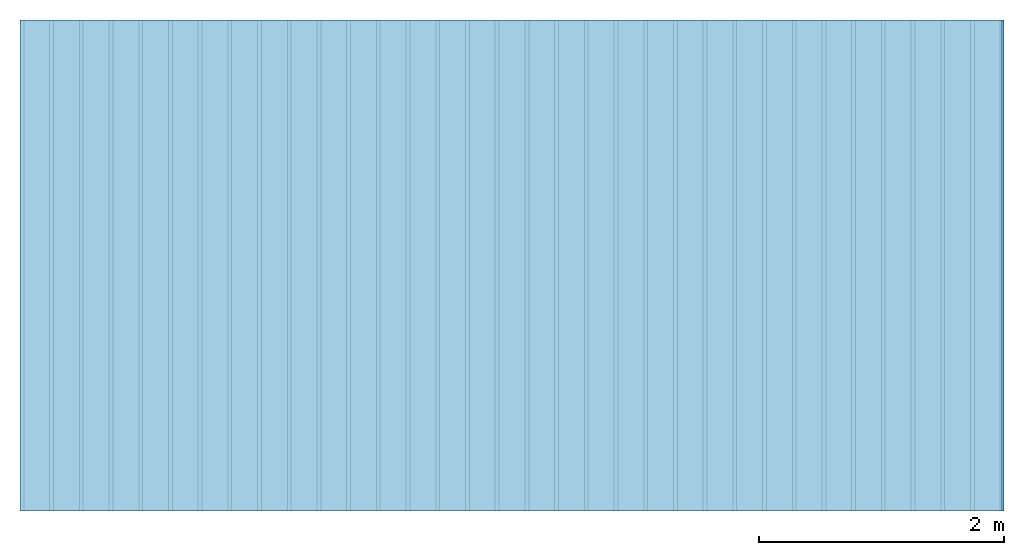
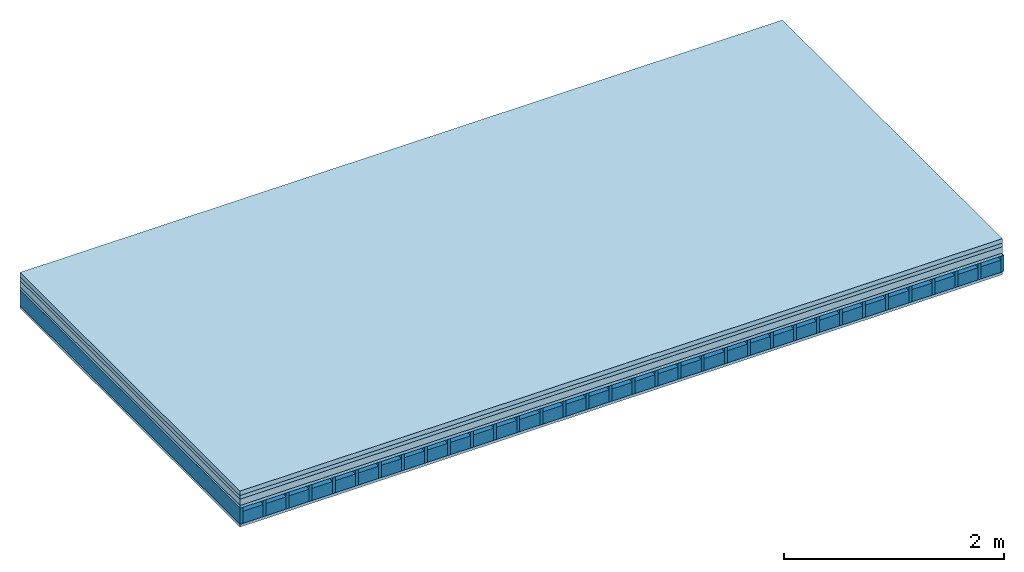
# One storey: 5 plates, 2 members, 1 element without a shape of its own.
"""IFC4 building model written with IfcOpenShell, lengths in metres."""

from ifc_helpers import new_model, si_unit, derived_unit, direction, frame, frame_2d, origin, origin_with_axes, place, context, project, spatial, rectangle, extrude, material, layer, layer_set, type_object, element, aggregate, save


model = new_model("IFC4")

# Units and contexts
plan_context = context("Plan", 3, precision=1e-05, world=origin(), true_north=direction((0.0, 1.0)))
model_context = context("Model", 3, precision=1e-05, world=origin(), true_north=direction((0.0, 1.0)))
ifc_project = project(units=[si_unit("LENGTHUNIT", "METRE"), derived_unit("SOUNDPRESSUREUNIT", [(si_unit("PRESSUREUNIT", "PASCAL", prefix="MICRO"), 0)]), si_unit("ENERGYUNIT", "JOULE", prefix="MEGA"), si_unit("MASSUNIT", "GRAM", prefix="KILO"), derived_unit("THERMALTRANSMITTANCEUNIT", [(si_unit("POWERUNIT", "WATT"), 1), (si_unit("AREAUNIT", "SQUARE_METRE"), -1), (si_unit("THERMODYNAMICTEMPERATUREUNIT", "KELVIN"), -1)]), derived_unit("AREADENSITYUNIT", [(si_unit("MASSUNIT", "GRAM", prefix="KILO"), 1), (si_unit("AREAUNIT", "SQUARE_METRE"), -1)]), derived_unit("USERDEFINED", [(si_unit("ENERGYUNIT", "JOULE", prefix="MEGA"), 1), (si_unit("AREAUNIT", "SQUARE_METRE"), -1)])], contexts=[plan_context, model_context])

# Site, building, storey
site = spatial("IfcSite", under=ifc_project)
building_placement = place(None, origin())
building = spatial("IfcBuilding", under=site, at=building_placement)
storey_placement = place(building_placement, origin())
storey = spatial("IfcBuildingStorey", under=building, at=storey_placement)

# Slab, members, plates
ifc_material_1 = material(Name="Cement screed", Category="04.006")
ifc_layer_1 = layer(ifc_material_1, 0.05, Name="On-material")
ifc_material_2 = material(Name="EP1, 40/35mm")
ifc_layer_2 = layer(ifc_material_2, 0.04, Name="Impact sound insulation")
ifc_material_3 = material(Category="03.011")
ifc_layer_3 = layer(ifc_material_3, 0.07, Name="on Supporting structure")
ifc_material_4 = material(Name="surface element sheathing above")
ifc_layer_4 = layer(ifc_material_4, 0.031, Name="Sub-floor")
ifc_layer_5 = layer(None, 0.178, Name="Supporting structure")
ifc_material_5 = material(Name="surface element sheathing below")
ifc_layer_6 = layer(ifc_material_5, 0.031, Name="Lower layer 1")
ifc_layer_set = layer_set([ifc_layer_1, ifc_layer_2, ifc_layer_3, ifc_layer_4, ifc_layer_5, ifc_layer_6])
slab_type = type_object("IfcSlabType", Name="A1466", PredefinedType="NOTDEFINED", material=ifc_layer_set)
slab_placement = place(None, frame((0.0, 0.0, 0.0), z_axis=(0.0, 0.0, -1.0), x_axis=(1.0, 0.0, 0.0)))
slab = element("IfcSlab", 1, at=slab_placement, inside=storey, type_object=slab_type, material=ifc_layer_set, Name="Slab #1")
ifc_material_6 = material(Name="surface element LFE 12")
member_1_placement = place(slab_placement, origin())
member_1 = element("IfcMember", 2, at=member_1_placement, material=ifc_material_6, Name="Supporting structure", context=plan_context, shape_type="SweptSolid", body=[
    extrude(rectangle(XDim=0.031, YDim=0.178, at=frame_2d((0.0155, 0.089), x_axis=(1.0, 0.0))), frame((0.0, 4.0, 0.191), z_axis=(0.0, -1.0, 0.0), x_axis=(1.0, 0.0, 0.0)), (0.0, 0.0, 1.0), 4.0),
    extrude(rectangle(XDim=0.031, YDim=0.178, at=frame_2d((0.0155, 0.089), x_axis=(1.0, 0.0))), frame((0.242, 4.0, 0.191), z_axis=(0.0, -1.0, 0.0), x_axis=(1.0, 0.0, 0.0)), (0.0, 0.0, 1.0), 4.0),
    extrude(rectangle(XDim=0.031, YDim=0.178, at=frame_2d((0.0155, 0.089), x_axis=(1.0, 0.0))), frame((0.484, 4.0, 0.191), z_axis=(0.0, -1.0, 0.0), x_axis=(1.0, 0.0, 0.0)), (0.0, 0.0, 1.0), 4.0),
    extrude(rectangle(XDim=0.031, YDim=0.178, at=frame_2d((0.0155, 0.089), x_axis=(1.0, 0.0))), frame((0.726, 4.0, 0.191), z_axis=(0.0, -1.0, 0.0), x_axis=(1.0, 0.0, 0.0)), (0.0, 0.0, 1.0), 4.0),
    extrude(rectangle(XDim=0.031, YDim=0.178, at=frame_2d((0.0155, 0.089), x_axis=(1.0, 0.0))), frame((0.968, 4.0, 0.191), z_axis=(0.0, -1.0, 0.0), x_axis=(1.0, 0.0, 0.0)), (0.0, 0.0, 1.0), 4.0),
    extrude(rectangle(XDim=0.031, YDim=0.178, at=frame_2d((0.0155, 0.089), x_axis=(1.0, 0.0))), frame((1.21, 4.0, 0.191), z_axis=(0.0, -1.0, 0.0), x_axis=(1.0, 0.0, 0.0)), (0.0, 0.0, 1.0), 4.0),
    extrude(rectangle(XDim=0.031, YDim=0.178, at=frame_2d((0.0155, 0.089), x_axis=(1.0, 0.0))), frame((1.452, 4.0, 0.191), z_axis=(0.0, -1.0, 0.0), x_axis=(1.0, 0.0, 0.0)), (0.0, 0.0, 1.0), 4.0),
    extrude(rectangle(XDim=0.031, YDim=0.178, at=frame_2d((0.0155, 0.089), x_axis=(1.0, 0.0))), frame((1.694, 4.0, 0.191), z_axis=(0.0, -1.0, 0.0), x_axis=(1.0, 0.0, 0.0)), (0.0, 0.0, 1.0), 4.0),
    extrude(rectangle(XDim=0.031, YDim=0.178, at=frame_2d((0.0155, 0.089), x_axis=(1.0, 0.0))), frame((1.936, 4.0, 0.191), z_axis=(0.0, -1.0, 0.0), x_axis=(1.0, 0.0, 0.0)), (0.0, 0.0, 1.0), 4.0),
    extrude(rectangle(XDim=0.031, YDim=0.178, at=frame_2d((0.0155, 0.089), x_axis=(1.0, 0.0))), frame((2.178, 4.0, 0.191), z_axis=(0.0, -1.0, 0.0), x_axis=(1.0, 0.0, 0.0)), (0.0, 0.0, 1.0), 4.0),
    extrude(rectangle(XDim=0.031, YDim=0.178, at=frame_2d((0.0155, 0.089), x_axis=(1.0, 0.0))), frame((2.42, 4.0, 0.191), z_axis=(0.0, -1.0, 0.0), x_axis=(1.0, 0.0, 0.0)), (0.0, 0.0, 1.0), 4.0),
    extrude(rectangle(XDim=0.031, YDim=0.178, at=frame_2d((0.0155, 0.089), x_axis=(1.0, 0.0))), frame((2.662, 4.0, 0.191), z_axis=(0.0, -1.0, 0.0), x_axis=(1.0, 0.0, 0.0)), (0.0, 0.0, 1.0), 4.0),
    extrude(rectangle(XDim=0.031, YDim=0.178, at=frame_2d((0.0155, 0.089), x_axis=(1.0, 0.0))), frame((2.904, 4.0, 0.191), z_axis=(0.0, -1.0, 0.0), x_axis=(1.0, 0.0, 0.0)), (0.0, 0.0, 1.0), 4.0),
    extrude(rectangle(XDim=0.031, YDim=0.178, at=frame_2d((0.0155, 0.089), x_axis=(1.0, 0.0))), frame((3.146, 4.0, 0.191), z_axis=(0.0, -1.0, 0.0), x_axis=(1.0, 0.0, 0.0)), (0.0, 0.0, 1.0), 4.0),
    extrude(rectangle(XDim=0.031, YDim=0.178, at=frame_2d((0.0155, 0.089), x_axis=(1.0, 0.0))), frame((3.388, 4.0, 0.191), z_axis=(0.0, -1.0, 0.0), x_axis=(1.0, 0.0, 0.0)), (0.0, 0.0, 1.0), 4.0),
    extrude(rectangle(XDim=0.031, YDim=0.178, at=frame_2d((0.0155, 0.089), x_axis=(1.0, 0.0))), frame((3.63, 4.0, 0.191), z_axis=(0.0, -1.0, 0.0), x_axis=(1.0, 0.0, 0.0)), (0.0, 0.0, 1.0), 4.0),
    extrude(rectangle(XDim=0.031, YDim=0.178, at=frame_2d((0.0155, 0.089), x_axis=(1.0, 0.0))), frame((3.872, 4.0, 0.191), z_axis=(0.0, -1.0, 0.0), x_axis=(1.0, 0.0, 0.0)), (0.0, 0.0, 1.0), 4.0),
    extrude(rectangle(XDim=0.031, YDim=0.178, at=frame_2d((0.0155, 0.089), x_axis=(1.0, 0.0))), frame((4.114, 4.0, 0.191), z_axis=(0.0, -1.0, 0.0), x_axis=(1.0, 0.0, 0.0)), (0.0, 0.0, 1.0), 4.0),
    extrude(rectangle(XDim=0.031, YDim=0.178, at=frame_2d((0.0155, 0.089), x_axis=(1.0, 0.0))), frame((4.356, 4.0, 0.191), z_axis=(0.0, -1.0, 0.0), x_axis=(1.0, 0.0, 0.0)), (0.0, 0.0, 1.0), 4.0),
    extrude(rectangle(XDim=0.031, YDim=0.178, at=frame_2d((0.0155, 0.089), x_axis=(1.0, 0.0))), frame((4.598, 4.0, 0.191), z_axis=(0.0, -1.0, 0.0), x_axis=(1.0, 0.0, 0.0)), (0.0, 0.0, 1.0), 4.0),
    extrude(rectangle(XDim=0.031, YDim=0.178, at=frame_2d((0.0155, 0.089), x_axis=(1.0, 0.0))), frame((4.84, 4.0, 0.191), z_axis=(0.0, -1.0, 0.0), x_axis=(1.0, 0.0, 0.0)), (0.0, 0.0, 1.0), 4.0),
    extrude(rectangle(XDim=0.031, YDim=0.178, at=frame_2d((0.0155, 0.089), x_axis=(1.0, 0.0))), frame((5.082, 4.0, 0.191), z_axis=(0.0, -1.0, 0.0), x_axis=(1.0, 0.0, 0.0)), (0.0, 0.0, 1.0), 4.0),
    extrude(rectangle(XDim=0.031, YDim=0.178, at=frame_2d((0.0155, 0.089), x_axis=(1.0, 0.0))), frame((5.324, 4.0, 0.191), z_axis=(0.0, -1.0, 0.0), x_axis=(1.0, 0.0, 0.0)), (0.0, 0.0, 1.0), 4.0),
    extrude(rectangle(XDim=0.031, YDim=0.178, at=frame_2d((0.0155, 0.089), x_axis=(1.0, 0.0))), frame((5.566, 4.0, 0.191), z_axis=(0.0, -1.0, 0.0), x_axis=(1.0, 0.0, 0.0)), (0.0, 0.0, 1.0), 4.0),
    extrude(rectangle(XDim=0.031, YDim=0.178, at=frame_2d((0.0155, 0.089), x_axis=(1.0, 0.0))), frame((5.808, 4.0, 0.191), z_axis=(0.0, -1.0, 0.0), x_axis=(1.0, 0.0, 0.0)), (0.0, 0.0, 1.0), 4.0),
    extrude(rectangle(XDim=0.031, YDim=0.178, at=frame_2d((0.0155, 0.089), x_axis=(1.0, 0.0))), frame((6.05, 4.0, 0.191), z_axis=(0.0, -1.0, 0.0), x_axis=(1.0, 0.0, 0.0)), (0.0, 0.0, 1.0), 4.0),
    extrude(rectangle(XDim=0.031, YDim=0.178, at=frame_2d((0.0155, 0.089), x_axis=(1.0, 0.0))), frame((6.292, 4.0, 0.191), z_axis=(0.0, -1.0, 0.0), x_axis=(1.0, 0.0, 0.0)), (0.0, 0.0, 1.0), 4.0),
    extrude(rectangle(XDim=0.031, YDim=0.178, at=frame_2d((0.0155, 0.089), x_axis=(1.0, 0.0))), frame((6.534, 4.0, 0.191), z_axis=(0.0, -1.0, 0.0), x_axis=(1.0, 0.0, 0.0)), (0.0, 0.0, 1.0), 4.0),
    extrude(rectangle(XDim=0.031, YDim=0.178, at=frame_2d((0.0155, 0.089), x_axis=(1.0, 0.0))), frame((6.776, 4.0, 0.191), z_axis=(0.0, -1.0, 0.0), x_axis=(1.0, 0.0, 0.0)), (0.0, 0.0, 1.0), 4.0),
    extrude(rectangle(XDim=0.031, YDim=0.178, at=frame_2d((0.0155, 0.089), x_axis=(1.0, 0.0))), frame((7.018, 4.0, 0.191), z_axis=(0.0, -1.0, 0.0), x_axis=(1.0, 0.0, 0.0)), (0.0, 0.0, 1.0), 4.0),
    extrude(rectangle(XDim=0.031, YDim=0.178, at=frame_2d((0.0155, 0.089), x_axis=(1.0, 0.0))), frame((7.26, 4.0, 0.191), z_axis=(0.0, -1.0, 0.0), x_axis=(1.0, 0.0, 0.0)), (0.0, 0.0, 1.0), 4.0),
    extrude(rectangle(XDim=0.031, YDim=0.178, at=frame_2d((0.0155, 0.089), x_axis=(1.0, 0.0))), frame((7.502, 4.0, 0.191), z_axis=(0.0, -1.0, 0.0), x_axis=(1.0, 0.0, 0.0)), (0.0, 0.0, 1.0), 4.0),
    extrude(rectangle(XDim=0.031, YDim=0.178, at=frame_2d((0.0155, 0.089), x_axis=(1.0, 0.0))), frame((7.744, 4.0, 0.191), z_axis=(0.0, -1.0, 0.0), x_axis=(1.0, 0.0, 0.0)), (0.0, 0.0, 1.0), 4.0),
    extrude(rectangle(XDim=0.031, YDim=0.178, at=frame_2d((0.0155, 0.089), x_axis=(1.0, 0.0))), frame((7.986, 4.0, 0.191), z_axis=(0.0, -1.0, 0.0), x_axis=(1.0, 0.0, 0.0)), (0.0, 0.0, 1.0), 4.0),
])
ifc_material_7 = material(Name="Damper LFE 12")
member_2_placement = place(slab_placement, origin())
member_2 = element("IfcMember", 3, at=member_2_placement, material=ifc_material_7, Name="in supporting structure", context=plan_context, shape_type="SweptSolid", body=[
    extrude(rectangle(XDim=0.211, YDim=0.135, at=frame_2d((0.1055, 0.0675), x_axis=(1.0, 0.0))), frame((0.031, 4.0, 0.234), z_axis=(0.0, -1.0, 0.0), x_axis=(1.0, 0.0, 0.0)), (0.0, 0.0, 1.0), 4.0),
    extrude(rectangle(XDim=0.211, YDim=0.135, at=frame_2d((0.1055, 0.0675), x_axis=(1.0, 0.0))), frame((0.273, 4.0, 0.234), z_axis=(0.0, -1.0, 0.0), x_axis=(1.0, 0.0, 0.0)), (0.0, 0.0, 1.0), 4.0),
    extrude(rectangle(XDim=0.211, YDim=0.135, at=frame_2d((0.1055, 0.0675), x_axis=(1.0, 0.0))), frame((0.515, 4.0, 0.234), z_axis=(0.0, -1.0, 0.0), x_axis=(1.0, 0.0, 0.0)), (0.0, 0.0, 1.0), 4.0),
    extrude(rectangle(XDim=0.211, YDim=0.135, at=frame_2d((0.1055, 0.0675), x_axis=(1.0, 0.0))), frame((0.757, 4.0, 0.234), z_axis=(0.0, -1.0, 0.0), x_axis=(1.0, 0.0, 0.0)), (0.0, 0.0, 1.0), 4.0),
    extrude(rectangle(XDim=0.211, YDim=0.135, at=frame_2d((0.1055, 0.0675), x_axis=(1.0, 0.0))), frame((0.999, 4.0, 0.234), z_axis=(0.0, -1.0, 0.0), x_axis=(1.0, 0.0, 0.0)), (0.0, 0.0, 1.0), 4.0),
    extrude(rectangle(XDim=0.211, YDim=0.135, at=frame_2d((0.1055, 0.0675), x_axis=(1.0, 0.0))), frame((1.241, 4.0, 0.234), z_axis=(0.0, -1.0, 0.0), x_axis=(1.0, 0.0, 0.0)), (0.0, 0.0, 1.0), 4.0),
    extrude(rectangle(XDim=0.211, YDim=0.135, at=frame_2d((0.1055, 0.0675), x_axis=(1.0, 0.0))), frame((1.483, 4.0, 0.234), z_axis=(0.0, -1.0, 0.0), x_axis=(1.0, 0.0, 0.0)), (0.0, 0.0, 1.0), 4.0),
    extrude(rectangle(XDim=0.211, YDim=0.135, at=frame_2d((0.1055, 0.0675), x_axis=(1.0, 0.0))), frame((1.725, 4.0, 0.234), z_axis=(0.0, -1.0, 0.0), x_axis=(1.0, 0.0, 0.0)), (0.0, 0.0, 1.0), 4.0),
    extrude(rectangle(XDim=0.211, YDim=0.135, at=frame_2d((0.1055, 0.0675), x_axis=(1.0, 0.0))), frame((1.967, 4.0, 0.234), z_axis=(0.0, -1.0, 0.0), x_axis=(1.0, 0.0, 0.0)), (0.0, 0.0, 1.0), 4.0),
    extrude(rectangle(XDim=0.211, YDim=0.135, at=frame_2d((0.1055, 0.0675), x_axis=(1.0, 0.0))), frame((2.209, 4.0, 0.234), z_axis=(0.0, -1.0, 0.0), x_axis=(1.0, 0.0, 0.0)), (0.0, 0.0, 1.0), 4.0),
    extrude(rectangle(XDim=0.211, YDim=0.135, at=frame_2d((0.1055, 0.0675), x_axis=(1.0, 0.0))), frame((2.451, 4.0, 0.234), z_axis=(0.0, -1.0, 0.0), x_axis=(1.0, 0.0, 0.0)), (0.0, 0.0, 1.0), 4.0),
    extrude(rectangle(XDim=0.211, YDim=0.135, at=frame_2d((0.1055, 0.0675), x_axis=(1.0, 0.0))), frame((2.693, 4.0, 0.234), z_axis=(0.0, -1.0, 0.0), x_axis=(1.0, 0.0, 0.0)), (0.0, 0.0, 1.0), 4.0),
    extrude(rectangle(XDim=0.211, YDim=0.135, at=frame_2d((0.1055, 0.0675), x_axis=(1.0, 0.0))), frame((2.935, 4.0, 0.234), z_axis=(0.0, -1.0, 0.0), x_axis=(1.0, 0.0, 0.0)), (0.0, 0.0, 1.0), 4.0),
    extrude(rectangle(XDim=0.211, YDim=0.135, at=frame_2d((0.1055, 0.0675), x_axis=(1.0, 0.0))), frame((3.177, 4.0, 0.234), z_axis=(0.0, -1.0, 0.0), x_axis=(1.0, 0.0, 0.0)), (0.0, 0.0, 1.0), 4.0),
    extrude(rectangle(XDim=0.211, YDim=0.135, at=frame_2d((0.1055, 0.0675), x_axis=(1.0, 0.0))), frame((3.419, 4.0, 0.234), z_axis=(0.0, -1.0, 0.0), x_axis=(1.0, 0.0, 0.0)), (0.0, 0.0, 1.0), 4.0),
    extrude(rectangle(XDim=0.211, YDim=0.135, at=frame_2d((0.1055, 0.0675), x_axis=(1.0, 0.0))), frame((3.661, 4.0, 0.234), z_axis=(0.0, -1.0, 0.0), x_axis=(1.0, 0.0, 0.0)), (0.0, 0.0, 1.0), 4.0),
    extrude(rectangle(XDim=0.211, YDim=0.135, at=frame_2d((0.1055, 0.0675), x_axis=(1.0, 0.0))), frame((3.903, 4.0, 0.234), z_axis=(0.0, -1.0, 0.0), x_axis=(1.0, 0.0, 0.0)), (0.0, 0.0, 1.0), 4.0),
    extrude(rectangle(XDim=0.211, YDim=0.135, at=frame_2d((0.1055, 0.0675), x_axis=(1.0, 0.0))), frame((4.145, 4.0, 0.234), z_axis=(0.0, -1.0, 0.0), x_axis=(1.0, 0.0, 0.0)), (0.0, 0.0, 1.0), 4.0),
    extrude(rectangle(XDim=0.211, YDim=0.135, at=frame_2d((0.1055, 0.0675), x_axis=(1.0, 0.0))), frame((4.387, 4.0, 0.234), z_axis=(0.0, -1.0, 0.0), x_axis=(1.0, 0.0, 0.0)), (0.0, 0.0, 1.0), 4.0),
    extrude(rectangle(XDim=0.211, YDim=0.135, at=frame_2d((0.1055, 0.0675), x_axis=(1.0, 0.0))), frame((4.629, 4.0, 0.234), z_axis=(0.0, -1.0, 0.0), x_axis=(1.0, 0.0, 0.0)), (0.0, 0.0, 1.0), 4.0),
    extrude(rectangle(XDim=0.211, YDim=0.135, at=frame_2d((0.1055, 0.0675), x_axis=(1.0, 0.0))), frame((4.871, 4.0, 0.234), z_axis=(0.0, -1.0, 0.0), x_axis=(1.0, 0.0, 0.0)), (0.0, 0.0, 1.0), 4.0),
    extrude(rectangle(XDim=0.211, YDim=0.135, at=frame_2d((0.1055, 0.0675), x_axis=(1.0, 0.0))), frame((5.113, 4.0, 0.234), z_axis=(0.0, -1.0, 0.0), x_axis=(1.0, 0.0, 0.0)), (0.0, 0.0, 1.0), 4.0),
    extrude(rectangle(XDim=0.211, YDim=0.135, at=frame_2d((0.1055, 0.0675), x_axis=(1.0, 0.0))), frame((5.355, 4.0, 0.234), z_axis=(0.0, -1.0, 0.0), x_axis=(1.0, 0.0, 0.0)), (0.0, 0.0, 1.0), 4.0),
    extrude(rectangle(XDim=0.211, YDim=0.135, at=frame_2d((0.1055, 0.0675), x_axis=(1.0, 0.0))), frame((5.597, 4.0, 0.234), z_axis=(0.0, -1.0, 0.0), x_axis=(1.0, 0.0, 0.0)), (0.0, 0.0, 1.0), 4.0),
    extrude(rectangle(XDim=0.211, YDim=0.135, at=frame_2d((0.1055, 0.0675), x_axis=(1.0, 0.0))), frame((5.839, 4.0, 0.234), z_axis=(0.0, -1.0, 0.0), x_axis=(1.0, 0.0, 0.0)), (0.0, 0.0, 1.0), 4.0),
    extrude(rectangle(XDim=0.211, YDim=0.135, at=frame_2d((0.1055, 0.0675), x_axis=(1.0, 0.0))), frame((6.081, 4.0, 0.234), z_axis=(0.0, -1.0, 0.0), x_axis=(1.0, 0.0, 0.0)), (0.0, 0.0, 1.0), 4.0),
    extrude(rectangle(XDim=0.211, YDim=0.135, at=frame_2d((0.1055, 0.0675), x_axis=(1.0, 0.0))), frame((6.323, 4.0, 0.234), z_axis=(0.0, -1.0, 0.0), x_axis=(1.0, 0.0, 0.0)), (0.0, 0.0, 1.0), 4.0),
    extrude(rectangle(XDim=0.211, YDim=0.135, at=frame_2d((0.1055, 0.0675), x_axis=(1.0, 0.0))), frame((6.565, 4.0, 0.234), z_axis=(0.0, -1.0, 0.0), x_axis=(1.0, 0.0, 0.0)), (0.0, 0.0, 1.0), 4.0),
    extrude(rectangle(XDim=0.211, YDim=0.135, at=frame_2d((0.1055, 0.0675), x_axis=(1.0, 0.0))), frame((6.807, 4.0, 0.234), z_axis=(0.0, -1.0, 0.0), x_axis=(1.0, 0.0, 0.0)), (0.0, 0.0, 1.0), 4.0),
    extrude(rectangle(XDim=0.211, YDim=0.135, at=frame_2d((0.1055, 0.0675), x_axis=(1.0, 0.0))), frame((7.049, 4.0, 0.234), z_axis=(0.0, -1.0, 0.0), x_axis=(1.0, 0.0, 0.0)), (0.0, 0.0, 1.0), 4.0),
    extrude(rectangle(XDim=0.211, YDim=0.135, at=frame_2d((0.1055, 0.0675), x_axis=(1.0, 0.0))), frame((7.291, 4.0, 0.234), z_axis=(0.0, -1.0, 0.0), x_axis=(1.0, 0.0, 0.0)), (0.0, 0.0, 1.0), 4.0),
    extrude(rectangle(XDim=0.211, YDim=0.135, at=frame_2d((0.1055, 0.0675), x_axis=(1.0, 0.0))), frame((7.533, 4.0, 0.234), z_axis=(0.0, -1.0, 0.0), x_axis=(1.0, 0.0, 0.0)), (0.0, 0.0, 1.0), 4.0),
    extrude(rectangle(XDim=0.211, YDim=0.135, at=frame_2d((0.1055, 0.0675), x_axis=(1.0, 0.0))), frame((7.775, 4.0, 0.234), z_axis=(0.0, -1.0, 0.0), x_axis=(1.0, 0.0, 0.0)), (0.0, 0.0, 1.0), 4.0),
])
plate_1_placement = place(slab_placement, origin())
plate_1 = element("IfcPlate", 4, at=plate_1_placement, material=ifc_material_1, Name="On-material", context=plan_context, shape_type="SweptSolid", body=[
    extrude(rectangle(XDim=8.0, YDim=4.0, at=frame_2d((4.0, 2.0), x_axis=(1.0, 0.0))), origin_with_axes(), (0.0, 0.0, 1.0), 0.05),
])
plate_2_placement = place(slab_placement, origin())
plate_2 = element("IfcPlate", 5, at=plate_2_placement, material=ifc_material_2, Name="Impact sound insulation", context=plan_context, shape_type="SweptSolid", body=[
    extrude(rectangle(XDim=8.0, YDim=4.0, at=frame_2d((4.0, 2.0), x_axis=(1.0, 0.0))), frame((0.0, 0.0, 0.05), z_axis=(0.0, 0.0, 1.0), x_axis=(1.0, 0.0, 0.0)), (0.0, 0.0, 1.0), 0.04),
])
plate_3_placement = place(slab_placement, origin())
plate_3 = element("IfcPlate", 6, at=plate_3_placement, material=ifc_material_3, Name="on Supporting structure", context=plan_context, shape_type="SweptSolid", body=[
    extrude(rectangle(XDim=8.0, YDim=4.0, at=frame_2d((4.0, 2.0), x_axis=(1.0, 0.0))), frame((0.0, 0.0, 0.09), z_axis=(0.0, 0.0, 1.0), x_axis=(1.0, 0.0, 0.0)), (0.0, 0.0, 1.0), 0.07),
])
plate_4_placement = place(slab_placement, origin())
plate_4 = element("IfcPlate", 7, at=plate_4_placement, material=ifc_material_4, Name="Sub-floor", context=plan_context, shape_type="SweptSolid", body=[
    extrude(rectangle(XDim=8.0, YDim=4.0, at=frame_2d((4.0, 2.0), x_axis=(1.0, 0.0))), frame((0.0, 0.0, 0.16), z_axis=(0.0, 0.0, 1.0), x_axis=(1.0, 0.0, 0.0)), (0.0, 0.0, 1.0), 0.031),
])
plate_5_placement = place(slab_placement, origin())
plate_5 = element("IfcPlate", 8, at=plate_5_placement, material=ifc_material_5, Name="Lower layer 1", context=plan_context, shape_type="SweptSolid", body=[
    extrude(rectangle(XDim=8.0, YDim=4.0, at=frame_2d((4.0, 2.0), x_axis=(1.0, 0.0))), frame((0.0, 0.0, 0.369), z_axis=(0.0, 0.0, 1.0), x_axis=(1.0, 0.0, 0.0)), (0.0, 0.0, 1.0), 0.031),
])
aggregate(slab, [plate_1, plate_2, plate_3, plate_4, member_1, member_2, plate_5])

save(model, "model.ifc")
